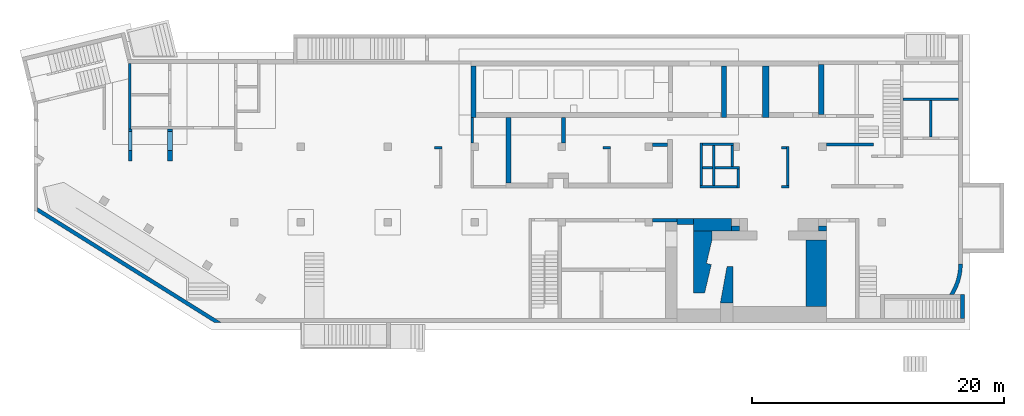
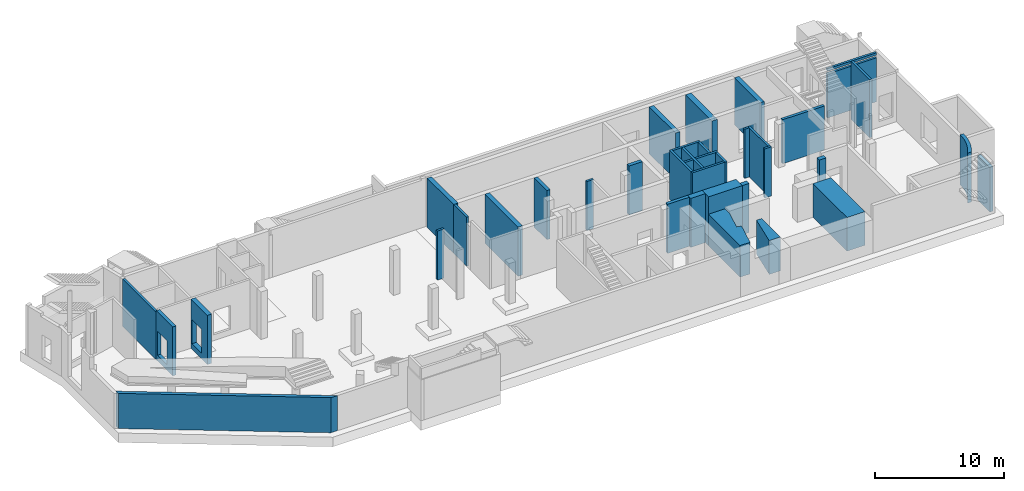
# One storey, part 3 of 9: 37 walls, 4 openings.
"""IFC4 building model written with IfcOpenShell, lengths in millimetres."""

from ifc_helpers import new_model, entity, si_unit, converted_unit, derived_unit, direction, frame, origin, place, context, subcontext, project, spatial, indexed_curve, outline, extrude, polygons, material, type_object, element, save


model = new_model("IFC4")

# Units and contexts
model_context = context("Model", 3, precision=0.01, world=origin(), true_north=direction((6.12303176911189e-17, 1.0)))
plan_context = context("Plan", 3, precision=0.01, world=origin(), true_north=direction((6.12303176911189e-17, 1.0)))
body_context = subcontext(model_context, "Body", "Model", "MODEL_VIEW")
ifc_project = project(units=[si_unit("LENGTHUNIT", "METRE", prefix="MILLI"), si_unit("AREAUNIT", "SQUARE_METRE"), si_unit("VOLUMEUNIT", "CUBIC_METRE"), converted_unit("PLANEANGLEUNIT", "DEGREE", entity("IfcRatioMeasure", 0.0174532925199433), si_unit("PLANEANGLEUNIT", "RADIAN"), dimensions=[0, 0, 0, 0, 0, 0, 0]), si_unit("MASSUNIT", "GRAM", prefix="KILO"), derived_unit("MASSDENSITYUNIT", [(si_unit("MASSUNIT", "GRAM", prefix="KILO"), 1), (si_unit("LENGTHUNIT", "METRE"), -3)]), derived_unit("MOMENTOFINERTIAUNIT", [(si_unit("LENGTHUNIT", "METRE"), 4)]), si_unit("TIMEUNIT", "SECOND"), si_unit("FREQUENCYUNIT", "HERTZ"), si_unit("THERMODYNAMICTEMPERATUREUNIT", "DEGREE_CELSIUS"), derived_unit("THERMALTRANSMITTANCEUNIT", [(si_unit("MASSUNIT", "GRAM", prefix="KILO"), 1), (si_unit("THERMODYNAMICTEMPERATUREUNIT", "KELVIN"), -1), (si_unit("TIMEUNIT", "SECOND"), -3)]), derived_unit("VOLUMETRICFLOWRATEUNIT", [(si_unit("LENGTHUNIT", "METRE"), 3), (si_unit("TIMEUNIT", "SECOND"), -1)]), derived_unit("MASSFLOWRATEUNIT", [(si_unit("MASSUNIT", "GRAM", prefix="KILO"), 1), (si_unit("TIMEUNIT", "SECOND"), -1)]), derived_unit("ROTATIONALFREQUENCYUNIT", [(si_unit("TIMEUNIT", "SECOND"), -1)]), si_unit("ELECTRICCURRENTUNIT", "AMPERE"), si_unit("ELECTRICVOLTAGEUNIT", "VOLT"), si_unit("POWERUNIT", "WATT"), si_unit("FORCEUNIT", "NEWTON", prefix="KILO"), si_unit("ILLUMINANCEUNIT", "LUX"), si_unit("LUMINOUSFLUXUNIT", "LUMEN"), si_unit("LUMINOUSINTENSITYUNIT", "CANDELA"), derived_unit("USERDEFINED", [(si_unit("MASSUNIT", "GRAM", prefix="KILO"), -1), (si_unit("LENGTHUNIT", "METRE"), -2), (si_unit("TIMEUNIT", "SECOND"), 3), (si_unit("LUMINOUSFLUXUNIT", "LUMEN"), 1)]), derived_unit("LINEARVELOCITYUNIT", [(si_unit("LENGTHUNIT", "METRE"), 1), (si_unit("TIMEUNIT", "SECOND"), -1)]), si_unit("PRESSUREUNIT", "PASCAL"), derived_unit("USERDEFINED", [(si_unit("LENGTHUNIT", "METRE"), -2), (si_unit("MASSUNIT", "GRAM", prefix="KILO"), 1), (si_unit("TIMEUNIT", "SECOND"), -2)]), derived_unit("LINEARFORCEUNIT", [(si_unit("MASSUNIT", "GRAM", prefix="KILO"), 1), (si_unit("LENGTHUNIT", "METRE"), 1), (si_unit("TIMEUNIT", "SECOND"), -2), (si_unit("LENGTHUNIT", "METRE"), -1)]), derived_unit("PLANARFORCEUNIT", [(si_unit("MASSUNIT", "GRAM", prefix="KILO"), 1), (si_unit("LENGTHUNIT", "METRE"), 1), (si_unit("TIMEUNIT", "SECOND"), -2), (si_unit("LENGTHUNIT", "METRE"), -2)])], contexts=[model_context, plan_context])

# Site, building, storey
site_placement = place(None, origin())
site = spatial("IfcSite", under=ifc_project, at=site_placement, CompositionType="ELEMENT")
building_placement = place(site_placement, origin())
building = spatial("IfcBuilding", under=site, at=building_placement, CompositionType="ELEMENT")
storey_placement = place(building_placement, frame((0.0, 0.0, -4900.0)))
storey = spatial("IfcBuildingStorey", under=building, at=storey_placement, CompositionType="ELEMENT", Elevation=-4900.0)

# Wall, opening
ifc_material = material()
wall_type_1 = type_object("IfcWallType", Name=":ADSK_ 25_200", PredefinedType="STANDARD")
placement_1 = place(storey_placement, frame((73370.0, 17470.0, 0.0), z_axis=(0.0, 0.0, 1.0), x_axis=(-1.0, 0.0, 0.0)))
wall_1 = element("IfcWall", 1, at=placement_1, inside=storey, type_object=wall_type_1, material=ifc_material, Name=":ADSK_ 25_200", ObjectType=":ADSK_ 25_200", PredefinedType="NOTDEFINED", context=body_context, shape_type="SweptSolid", body=[
    extrude(outline(indexed_curve([(4399.99999999998, 99.9999999999989), (-3.44548696094126e-13, 99.9999999999989), (3.44548696094126e-13, -99.9999999999989), (4399.99999999998, -99.9999999999989), (4399.99999999998, 99.9999999999989)], self_intersect=False)), origin(), (0.0, 0.0, 1.0), 4650.0),
])
element("IfcOpeningElement", 2, at=placement_1, cuts=wall_1, Name=":ADSK_ 25_200:1", PredefinedType="OPENING", context=body_context, shape_type="SweptSolid", body=[
    extrude(outline(indexed_curve([(-2199.99999999998, -100.0), (2199.99999999999, -100.0), (2199.99999999999, 100.0), (-2199.99999999999, 100.0), (-2199.99999999998, -100.0)], self_intersect=False)), frame((2200.0, 0.0, 4170.0)), (0.0, 0.0, 1.0), 250.0),
])

# Walls
wall_2_placement = place(storey_placement, frame((71170.0, 14470.0, -850.0), z_axis=(0.0, 0.0, 1.0), x_axis=(0.0, 1.0, 0.0)))
element("IfcWall", 3, at=wall_2_placement, inside=storey, type_object=wall_type_1, material=ifc_material, Name=":ADSK_ 25_200", ObjectType=":ADSK_ 25_200", PredefinedType="NOTDEFINED", context=body_context, shape_type="SweptSolid", body=[
    extrude(outline(indexed_curve([(2899.99999999951, 100.000000000003), (-2.98721966703065e-13, 100.000000000003), (2.98721966703065e-13, -100.000000000003), (2899.99999999951, -100.000000000003), (2899.99999999951, 100.000000000003)], self_intersect=False)), origin(), (0.0, 0.0, 1.0), 5500.0),
])
wall_3_placement = place(storey_placement, frame((34770.0, 16000.0, 0.0), z_axis=(0.0, 0.0, 1.0), x_axis=(0.0, -1.0, 0.0)))
element("IfcWall", 4, at=wall_3_placement, inside=storey, type_object=wall_type_1, material=ifc_material, Name=":ADSK_ 25_200", ObjectType=":ADSK_ 25_200", PredefinedType="NOTDEFINED", context=body_context, shape_type="SweptSolid", body=[
    extrude(outline(indexed_curve([(1999.99999999982, 99.9999999999989), (-2.16573425859696e-13, 99.9999999999989), (2.16573425859696e-13, -99.9999999999989), (1999.99999999982, -99.9999999999989), (1999.99999999982, 99.9999999999989)], self_intersect=False)), origin(), (0.0, 0.0, 1.0), 4650.0),
])
wall_4_placement = place(storey_placement, frame((59830.0, 10625.0, 0.0), z_axis=(0.0, 0.0, 1.0), x_axis=(0.0, 1.0, 0.0)))
element("IfcWall", 5, at=wall_4_placement, inside=storey, type_object=wall_type_1, material=ifc_material, Name=":ADSK_ 25_200", ObjectType=":ADSK_ 25_200", PredefinedType="NOTDEFINED", context=body_context, shape_type="SweptSolid", body=[
    extrude(outline(indexed_curve([(3075.0, 100.000000000004), (-3.08123216157509e-13, 100.000000000003), (3.08123216157509e-13, -100.000000000003), (3075.0, -100.000000000002), (3075.0, 100.000000000004)], self_intersect=False)), origin(), (0.0, 0.0, 1.0), 4650.0),
])
wall_5_placement = place(storey_placement, frame((59730.0, 13600.0, 0.0), z_axis=(0.0, 0.0, 1.0), x_axis=(-1.0, 0.0, 0.0)))
element("IfcWall", 6, at=wall_5_placement, inside=storey, type_object=wall_type_1, material=ifc_material, Name=":ADSK_ 25_200", ObjectType=":ADSK_ 25_200", PredefinedType="NOTDEFINED", context=body_context, shape_type="SweptSolid", body=[
    extrude(outline(indexed_curve([(400.000000000003, 99.9999999999983), (-9.28211303758498e-13, 99.9999999999989), (9.28211303758498e-13, -99.9999999999989), (400.000000000005, -99.9999999999995), (400.000000000003, 99.9999999999983)], self_intersect=False)), origin(), (0.0, 0.0, 1.0), 4650.0),
])
wall_6_placement = place(storey_placement, frame((59930.0, 10525.0, 0.0), z_axis=(0.0, 0.0, 1.0), x_axis=(-1.0, 0.0, 0.0)))
element("IfcWall", 7, at=wall_6_placement, inside=storey, type_object=wall_type_1, material=ifc_material, Name=":ADSK_ 25_200", ObjectType=":ADSK_ 25_200", PredefinedType="NOTDEFINED", context=body_context, shape_type="SweptSolid", body=[
    extrude(outline(indexed_curve([(600.00000000001, 99.999999999998), (-9.28211303758498e-13, 99.9999999999989), (9.28211303758498e-13, -99.9999999999989), (600.000000000012, -99.9999999999999), (600.00000000001, 99.999999999998)], self_intersect=False)), origin(), (0.0, 0.0, 1.0), 4650.0),
])
wall_7_placement = place(storey_placement, frame((55520.0, 13900.0, 0.0), z_axis=(0.0, 0.0, 1.0), x_axis=(-1.0, 0.0, 0.0)))
element("IfcWall", 8, at=wall_7_placement, inside=storey, type_object=wall_type_1, material=ifc_material, Name=":ADSK_ 25_200", ObjectType=":ADSK_ 25_200", PredefinedType="NOTDEFINED", context=body_context, shape_type="SweptSolid", body=[
    extrude(outline(indexed_curve([(2470.00000000003, 100.000000000001), (-3.39529745858372e-13, 99.9999999999989), (3.39529745858372e-13, -99.9999999999989), (2470.00000000003, -99.999999999997), (2470.00000000003, 100.000000000001)], self_intersect=False)), origin(), (0.0, 0.0, 1.0), 4650.0),
])
wall_8_placement = place(storey_placement, frame((52950.0, 14000.0, 0.0), z_axis=(0.0, 0.0, 1.0), x_axis=(0.0, -1.0, 0.0)))
element("IfcWall", 9, at=wall_8_placement, inside=storey, type_object=wall_type_1, material=ifc_material, Name=":ADSK_ 25_200", ObjectType=":ADSK_ 25_200", PredefinedType="NOTDEFINED", context=body_context, shape_type="SweptSolid", body=[
    extrude(outline(indexed_curve([(3375.00000000001, 100.000000000003), (0.0, 100.000000000003), (0.0, -100.000000000003), (3375.00000000001, -100.000000000003), (3375.00000000001, 100.000000000003)], self_intersect=False)), origin(), (0.0, 0.0, 1.0), 4650.0),
])
wall_9_placement = place(storey_placement, frame((53930.0, 13800.0, 0.0), z_axis=(0.0, 0.0, 1.0), x_axis=(0.0, -1.0, 0.0)))
element("IfcWall", 10, at=wall_9_placement, inside=storey, type_object=wall_type_1, material=ifc_material, Name=":ADSK_ 25_200", ObjectType=":ADSK_ 25_200", PredefinedType="NOTDEFINED", context=body_context, shape_type="SweptSolid", body=[
    extrude(outline(indexed_curve([(3175.00000000001, 100.000000000003), (0.0, 100.000000000003), (0.0, -100.000000000003), (3175.00000000001, -100.000000000003), (3175.00000000001, 100.000000000003)], self_intersect=False)), origin(), (0.0, 0.0, 1.0), 4650.0),
])

# Wall, opening
placement_2 = place(storey_placement, frame((53050.0, 12025.0, 0.0)))
wall_10 = element("IfcWall", 11, at=placement_2, inside=storey, type_object=wall_type_1, material=ifc_material, Name=":ADSK_ 25_200", ObjectType=":ADSK_ 25_200", PredefinedType="NOTDEFINED", context=body_context, shape_type="SweptSolid", body=[
    extrude(outline(indexed_curve([(2920.00000000003, 99.9999999999989), (0.0, 99.9999999999989), (0.0, -99.9999999999989), (2920.00000000003, -99.9999999999989), (2920.00000000003, 99.9999999999989)], self_intersect=False)), origin(), (0.0, 0.0, 1.0), 4650.0),
])
element("IfcOpeningElement", 12, at=placement_2, cuts=wall_10, Name=":ADSK_ 25_200:1", PredefinedType="OPENING", context=body_context, shape_type="SweptSolid", body=[
    extrude(outline(indexed_curve([(-2325.0, -100.000000000001), (2325.0, -100.000000000001), (2325.0, 99.9999999999989), (-2325.0, 99.9999999999989), (-2325.0, -100.000000000001)], self_intersect=False)), frame((780.0, 0.0, 2325.0), z_axis=(1.0, 0.0, 0.0), x_axis=(0.0, 0.0, -1.0)), (0.0, 0.0, 1.0), 199.999999999998),
])

# Walls
wall_11_placement = place(storey_placement, frame((55870.0, 11925.0, 0.0), z_axis=(0.0, 0.0, 1.0), x_axis=(0.0, -1.0, 0.0)))
element("IfcWall", 13, at=wall_11_placement, inside=storey, type_object=wall_type_1, material=ifc_material, Name=":ADSK_ 25_200", ObjectType=":ADSK_ 25_200", PredefinedType="NOTDEFINED", context=body_context, shape_type="SweptSolid", body=[
    extrude(outline(indexed_curve([(1500.0, 100.000000000003), (0.0, 100.000000000003), (0.0, -100.000000000003), (1500.0, -100.000000000003), (1500.0, 100.000000000003)], self_intersect=False)), origin(), (0.0, 0.0, 1.0), 4650.0),
])
wall_12_placement = place(storey_placement, frame((55420.0, 13800.0, 0.0), z_axis=(0.0, 0.0, 1.0), x_axis=(0.0, -1.0, 0.0)))
element("IfcWall", 14, at=wall_12_placement, inside=storey, type_object=wall_type_1, material=ifc_material, Name=":ADSK_ 25_200", ObjectType=":ADSK_ 25_200", PredefinedType="NOTDEFINED", context=body_context, shape_type="SweptSolid", body=[
    extrude(outline(indexed_curve([(1675.0, 100.000000000003), (0.0, 100.000000000003), (0.0, -100.000000000003), (1675.0, -100.000000000003), (1675.0, 100.000000000003)], self_intersect=False)), origin(), (0.0, 0.0, 1.0), 4650.0),
])
wall_13_placement = place(storey_placement, frame((55770.0, 10525.0, 0.0), z_axis=(0.0, 0.0, 1.0), x_axis=(-1.0, 0.0, 0.0)))
element("IfcWall", 15, at=wall_13_placement, inside=storey, type_object=wall_type_1, material=ifc_material, Name=":ADSK_ 25_200", ObjectType=":ADSK_ 25_200", PredefinedType="NOTDEFINED", context=body_context, shape_type="SweptSolid", body=[
    extrude(outline(indexed_curve([(2920.00000000003, 99.9999999999989), (0.0, 99.9999999999989), (0.0, -99.9999999999989), (2920.00000000003, -99.9999999999989), (2920.00000000003, 99.9999999999989)], self_intersect=False)), origin(), (0.0, 0.0, 1.0), 4650.0),
])
wall_14_placement = place(storey_placement, frame((45770.0, 13600.0, 0.0), z_axis=(0.0, 0.0, 1.0), x_axis=(-1.0, 0.0, 0.0)))
element("IfcWall", 16, at=wall_14_placement, inside=storey, type_object=wall_type_1, material=ifc_material, Name=":ADSK_ 25_200", ObjectType=":ADSK_ 25_200", PredefinedType="NOTDEFINED", context=body_context, shape_type="SweptSolid", body=[
    extrude(outline(indexed_curve([(600.000000000001, 99.9999999999989), (-1.08286712929837e-12, 99.9999999999989), (1.08286712929837e-12, -99.9999999999989), (600.000000000003, -99.9999999999989), (600.000000000001, 99.9999999999989)], self_intersect=False)), origin(), (0.0, 0.0, 1.0), 4650.0),
])
wall_15_placement = place(storey_placement, frame((32370.0, 13600.0, 0.0), z_axis=(0.0, 0.0, 1.0), x_axis=(-1.0, 0.0, 0.0)))
element("IfcWall", 17, at=wall_15_placement, inside=storey, type_object=wall_type_1, material=ifc_material, Name=":ADSK_ 25_200", ObjectType=":ADSK_ 25_200", PredefinedType="NOTDEFINED", context=body_context, shape_type="SweptSolid", body=[
    extrude(outline(indexed_curve([(600.000000000001, 99.9999999999984), (-9.89300764987533e-13, 99.9999999999989), (9.89300764987533e-13, -99.9999999999989), (600.000000000003, -99.9999999999995), (600.000000000001, 99.9999999999984)], self_intersect=False)), origin(), (0.0, 0.0, 1.0), 4650.0),
])
wall_16_placement = place(storey_placement, frame((7600.0, 20300.0, 0.0), z_axis=(0.0, 0.0, 1.0), x_axis=(0.0, -1.0, 0.0)))
element("IfcWall", 18, at=wall_16_placement, inside=storey, type_object=wall_type_1, material=ifc_material, Name=":ADSK_ 25_200", ObjectType=":ADSK_ 25_200", PredefinedType="NOTDEFINED", context=body_context, shape_type="Tessellation", body=[
    polygons([(0.0, -100.0, 0.0), (5200.00000000049, -99.9999999999999, 0.0), (5200.00000000049, -99.9999999999999, 4500.0), (0.0, -100.0, 4500.0), (5200.00000000049, 99.999999999999, 0.0), (5000.00000000049, 99.9999999999993, 0.0), (2600.0, 99.9999999999999, 0.0), (2400.0, 100.0, 0.0), (0.0, 99.9999999999997, 0.0), (0.0, 99.9999999999997, 4500.0), (5099.99936063356, 99.9999999999992, 4500.0), (5200.00000000049, 99.999999999999, 4500.0)], [[[1, 2, 3, 4]], [[5, 6, 7, 8, 9, 10, 11, 12]], [[2, 1, 9, 8, 7, 6, 5]], [[9, 1, 4, 10]], [[2, 5, 12, 3]], [[4, 3, 12, 11, 10]]], closed=True),
])
wall_type_2 = type_object("IfcWallType", Name=":ADSK_ 25_300", PredefinedType="STANDARD")
wall_17_placement = place(storey_placement, frame((220.51, 8728.24, 0.0), z_axis=(0.0, 0.0, 1.0), x_axis=(0.848052743777572, -0.529911826412028, 0.0)))
element("IfcWall", 19, at=wall_17_placement, inside=storey, type_object=wall_type_2, material=ifc_material, Name=":ADSK_ 25_300", ObjectType=":ADSK_ 25_300", PredefinedType="NOTDEFINED", context=body_context, shape_type="Tessellation", body=[
    polygons([(187.457147082002, -149.999999999999, 0.0), (16702.841510544, -150.000000000001, 0.0), (16702.841510544, -150.000000000001, 3330.0), (187.457147082001, -149.999999999999, 3330.0), (-1.08286712929839e-12, 150.000000000001, 0.0), (0.0, 150.000000000001, 3330.0), (16616.8193185591, 150.0, 3330.0), (17182.9512390927, 150.000000000001, 3330.0), (17182.9512390925, 149.999999999999, 0.0), (16616.8193185591, 150.000000000001, 0.0)], [[[1, 2, 3, 4]], [[5, 6, 7, 8, 9, 10]], [[2, 1, 5, 10, 9]], [[1, 4, 6, 5]], [[3, 2, 9, 8]], [[4, 3, 8, 7, 6]]], closed=True),
])
wall_18_placement = place(storey_placement, frame((49070.0, 7850.0, 0.0)))
element("IfcWall", 20, at=wall_18_placement, inside=storey, type_object=wall_type_2, material=ifc_material, Name=":ADSK_ 25_300", ObjectType=":ADSK_ 25_300", PredefinedType="NOTDEFINED", context=body_context, shape_type="SweptSolid", body=[
    extrude(outline(indexed_curve([(1950.0, 150.000000000001), (-5.11333990909232e-13, 150.000000000001), (5.11333990909232e-13, -150.000000000001), (1950.0, -150.0), (1950.0, 150.000000000001)], self_intersect=False)), origin(), (0.0, 0.0, 1.0), 4650.0),
])
wall_19_placement = place(storey_placement, frame((73675.0, 1945.0, 0.0), z_axis=(0.0, 0.0, 1.0), x_axis=(0.0, -1.0, 0.0)))
element("IfcWall", 21, at=wall_19_placement, inside=storey, type_object=wall_type_2, material=ifc_material, Name=":ADSK_ 25_300", ObjectType=":ADSK_ 25_300", PredefinedType="NOTDEFINED", context=body_context, shape_type="SweptSolid", body=[
    extrude(outline(indexed_curve([(1895.00000000003, 150.000000000001), (0.0, 150.000000000001), (0.0, -150.000000000001), (1895.00000000003, -150.000000000001), (1895.00000000003, 150.000000000001)], self_intersect=False)), origin(), (0.0, 0.0, 1.0), 4229.99999999996),
])
wall_20_placement = place(storey_placement, frame((49070.0, 13850.0, 0.0)))
element("IfcWall", 22, at=wall_20_placement, inside=storey, type_object=wall_type_2, material=ifc_material, Name=":ADSK_ 25_300", ObjectType=":ADSK_ 25_300", PredefinedType="NOTDEFINED", context=body_context, shape_type="SweptSolid", body=[
    extrude(outline(indexed_curve([(1200.0, 150.000000000001), (-5.41433564649196e-13, 150.000000000001), (5.41433564649196e-13, -150.000000000001), (1200.00000000001, -150.000000000001), (1200.0, 150.000000000001)], self_intersect=False)), origin(), (0.0, 0.0, 1.0), 4650.0),
])
wall_21_placement = place(storey_placement, frame((42020.0, 14000.0, 0.0), z_axis=(0.0, 0.0, 1.0), x_axis=(0.0, 1.0, 0.0)))
element("IfcWall", 23, at=wall_21_placement, inside=storey, type_object=wall_type_2, material=ifc_material, Name=":ADSK_ 25_300", ObjectType=":ADSK_ 25_300", PredefinedType="NOTDEFINED", context=body_context, shape_type="SweptSolid", body=[
    extrude(outline(indexed_curve([(1999.99999999982, 150.000000000001), (0.0, 150.000000000001), (0.0, -150.000000000001), (1999.99999999982, -150.000000000001), (1999.99999999982, 150.000000000001)], self_intersect=False)), origin(), (0.0, 0.0, 1.0), 4650.0),
])

# Wall, opening
wall_22_placement = place(storey_placement, frame((7650.0, 15100.0, 0.0), z_axis=(0.0, 0.0, 1.0), x_axis=(0.0, -1.0, 0.0)))
wall_22 = element("IfcWall", 24, at=wall_22_placement, inside=storey, type_object=wall_type_2, material=ifc_material, Name=":ADSK_ 25_300", ObjectType=":ADSK_ 25_300", PredefinedType="NOTDEFINED", context=body_context, shape_type="Tessellation", body=[
    polygons([(0.0, -149.999999999999, 0.0), (2559.99999999952, -149.999999999999, 0.0), (2559.99999999952, -149.999999999999, 4650.0), (0.0, -149.999999999999, 4650.0), (0.0, -149.999999999999, 4500.0), (199.999999999524, -149.999999999999, 2829.99999999804), (1699.99999999952, -150.0, 2829.99999999805), (1699.99999999952, -150.0, 550.0), (199.999999999521, -149.999999999999, 550.0), (2559.99999999952, 150.000000000001, 0.0), (0.0, 150.000000000001, 0.0), (0.0, 150.000000000001, 4650.0), (2559.99999999952, 150.000000000001, 4650.0), (1699.99999999952, 150.0, 2829.99999999805), (199.999999999521, 150.000000000001, 2829.99999999804), (199.999999999521, 150.000000000001, 550.0), (1699.99999999952, 150.0, 550.0), (0.0, 50.0000000000028, 0.0), (0.0, 50.0000000000039, 4650.0)], [[[1, 2, 3, 4, 5], [6, 7, 8, 9]], [[10, 11, 12, 13], [14, 15, 16, 17]], [[2, 1, 18, 11, 10]], [[3, 2, 10, 13]], [[4, 3, 13, 12, 19]], [[1, 5, 4, 19, 12, 11, 18]], [[14, 7, 6, 15]], [[15, 6, 9, 16]], [[16, 9, 8, 17]], [[7, 14, 17, 8]]], closed=True),
])
opening_3_placement = place(wall_22_placement, frame((15100.0, -7650.0, 0.0), z_axis=(0.0, 0.0, 1.0), x_axis=(0.0, 1.0, 0.0)))
element("IfcOpeningElement", 25, at=opening_3_placement, cuts=wall_22, Name=":ADSK_ 25_300", PredefinedType="OPENING", context=body_context, shape_type="SweptSolid", body=[
    extrude(outline(indexed_curve([(-1139.99999999902, -749.999999999998), (1139.99999999902, -749.999999999998), (1139.99999999902, 750.000000000001), (-1139.99999999902, 750.000000000001), (-1139.99999999902, -749.999999999998)], self_intersect=False)), frame((7400.0, 14150.0, 1690.0), z_axis=(1.0, 0.0, 0.0), x_axis=(0.0, 0.0, -1.0)), (0.0, 0.0, 1.0), 500.000000001943),
])

# Walls
wall_23_placement = place(storey_placement, frame((73520.0, 4400.0, 0.0)))
element("IfcWall", 26, at=wall_23_placement, inside=storey, type_object=wall_type_2, material=ifc_material, Name=":ADSK_ 25_300", ObjectType=":ADSK_ 25_300", PredefinedType="NOTDEFINED", context=body_context, shape_type="SweptSolid", body=[
    extrude(outline(indexed_curve([(-542.136329488565, -2454.9999999995), (-413.330459406746, -2231.13461263897), (-297.016369515146, -2000.53171517602), (-193.545301320908, -1763.88767474322), (-103.229713391773, -1521.91710132026), (-26.3423378039082, -1275.350689778), (36.8846434456006, -1024.93301334981), (86.2602995743678, -771.420275193577), (121.635527581284, -515.578024833953), (142.9035025029, -258.178846380812), (150.000000000001, -2.55048707444416e-05), (-149.999999999992, 2.55047527119245e-05), (-157.705892452505, -260.292278133518), (-180.796490186139, -519.67286416129), (-219.190914727773, -777.233211023775), (-272.754683528757, -1032.07117284195), (-341.300181011307, -1283.29413932128), (-424.587315721797, -1530.02216226056), (-522.324361289021, -1771.39103770973), (-634.168978242002, -2006.55533298103), (-759.729413108203, -2234.69134791076), (-898.565870592014, -2454.99999999949), (-542.136329488565, -2454.9999999995)], self_intersect=False)), origin(), (0.0, 0.0, 1.0), 4750.0),
])
wall_type_3 = type_object("IfcWallType", Name=":ADSK_ 25_250", PredefinedType="STANDARD")
wall_24_placement = place(storey_placement, frame((62870.0, 13875.0, 0.0)))
element("IfcWall", 27, at=wall_24_placement, inside=storey, type_object=wall_type_3, material=ifc_material, Name=":ADSK_ 25_250", ObjectType=":ADSK_ 25_250", PredefinedType="NOTDEFINED", context=body_context, shape_type="SweptSolid", body=[
    extrude(outline(indexed_curve([(3759.99999999999, 124.999999999999), (-3.94184035522033e-13, 125.0), (3.94184035522033e-13, -125.0), (3759.99999999999, -125.000000000001), (3759.99999999999, 124.999999999999)], self_intersect=False)), origin(), (0.0, 0.0, 1.0), 4170.0),
])
wall_type_4 = type_object("IfcWallType", Name=":ADSK_ 25_1000", PredefinedType="STANDARD")
wall_25_placement = place(storey_placement, frame((52320.0, 7500.0, 0.0)))
element("IfcWall", 28, at=wall_25_placement, inside=storey, type_object=wall_type_4, material=ifc_material, Name=":ADSK_ 25_1000", ObjectType=":ADSK_ 25_1000", PredefinedType="NOTDEFINED", context=body_context, shape_type="SweptSolid", body=[
    extrude(outline(indexed_curve([(3050.00000000001, 500.0), (-1.54352002599108e-12, 500.0), (1.54352002599108e-12, -500.0), (3050.00000000001, -500.0), (3050.00000000001, 500.0)], self_intersect=False)), origin(), (0.0, 0.0, 1.0), 4650.0),
])
wall_type_5 = type_object("IfcWallType", Name="1: 1", PredefinedType="NOTDEFINED", material=ifc_material)
wall_26_placement = place(storey_placement, frame((54470.0, 1300.0, 0.0), z_axis=(0.0, 0.0, 1.0), x_axis=(0.0, 1.0, 0.0)))
element("IfcWall", 29, at=wall_26_placement, inside=storey, type_object=wall_type_5, material=ifc_material, Name="1: 1", ObjectType="1: 1", PredefinedType="NOTDEFINED", context=body_context, shape_type="SweptSolid", body=[
    extrude(outline(indexed_curve([(-368.249999999999, -1450.0), (104.749999999998, -1450.0), (631.749999999999, 1450.0), (-368.249999999999, 1450.0), (-368.249999999999, -1450.0)], self_intersect=False)), frame((1450.0, -631.75, 0.0), z_axis=(0.0, 0.0, 1.0), x_axis=(0.0, 1.0, 0.0)), (0.0, 0.0, 1.0), 3200.0),
])
wall_type_6 = type_object("IfcWallType", Name=":ADSK_ 25_500", PredefinedType="STANDARD")
wall_27_placement = place(storey_placement, frame((50570.0, 7750.0, 0.0)))
element("IfcWall", 30, at=wall_27_placement, inside=storey, type_object=wall_type_6, material=ifc_material, Name=":ADSK_ 25_500", ObjectType=":ADSK_ 25_500", PredefinedType="NOTDEFINED", context=body_context, shape_type="SweptSolid", body=[
    extrude(outline(indexed_curve([(1750.0, -250.000000000001), (1750.0, 249.999999999999), (450.000000000001, 249.999999999999), (450.000000000002, -50.0000000000001), (450.000000000002, -250.000000000001), (1750.0, -250.000000000001)], self_intersect=False)), origin(), (0.0, 0.0, 1.0), 4650.0),
])
wall_28_placement = place(storey_placement, frame((58070.0, 20100.0, 0.0), z_axis=(0.0, 0.0, 1.0), x_axis=(0.0, -1.0, 0.0)))
element("IfcWall", 31, at=wall_28_placement, inside=storey, type_object=wall_type_6, material=ifc_material, Name=":ADSK_ 25_500", ObjectType=":ADSK_ 25_500", PredefinedType="NOTDEFINED", context=body_context, shape_type="SweptSolid", body=[
    extrude(outline(indexed_curve([(4100.00000000002, 250.000000000004), (0.0, 250.000000000004), (0.0, -250.000000000004), (4100.00000000002, -250.000000000004), (4100.00000000002, 250.000000000004)], self_intersect=False)), origin(), (0.0, 0.0, 1.0), 4450.0),
])
wall_type_7 = type_object("IfcWallType", Name=":ADSK_ 25_400", PredefinedType="STANDARD")
wall_29_placement = place(storey_placement, frame((55370.0, 7200.0, 0.0)))
element("IfcWall", 32, at=wall_29_placement, inside=storey, type_object=wall_type_7, material=ifc_material, Name=":ADSK_ 25_400", ObjectType=":ADSK_ 25_400", PredefinedType="NOTDEFINED", context=body_context, shape_type="SweptSolid", body=[
    extrude(outline(indexed_curve([(600.000000000001, 200.0), (-1.44382283906452e-12, 200.0), (1.44382283906452e-12, -200.0), (600.000000000004, -200.0), (600.000000000001, 200.0)], self_intersect=False)), origin(), (0.0, 0.0, 1.0), 4650.0),
])
wall_30_placement = place(storey_placement, frame((62270.0, 7200.0, 0.0)))
element("IfcWall", 33, at=wall_30_placement, inside=storey, type_object=wall_type_7, material=ifc_material, Name=":ADSK_ 25_400", ObjectType=":ADSK_ 25_400", PredefinedType="NOTDEFINED", context=body_context, shape_type="SweptSolid", body=[
    extrude(outline(indexed_curve([(600.000000000001, 200.0), (-7.21911419532259e-13, 200.0), (7.21911419532259e-13, -200.0), (600.000000000003, -200.0), (600.000000000001, 200.0)], self_intersect=False)), origin(), (0.0, 0.0, 1.0), 4650.0),
])
wall_31_placement = place(storey_placement, frame((62470.0, 20500.0, 0.0), z_axis=(0.0, 0.0, 1.0), x_axis=(0.0, -1.0, 0.0)))
element("IfcWall", 34, at=wall_31_placement, inside=storey, type_object=wall_type_7, material=ifc_material, Name=":ADSK_ 25_400", ObjectType=":ADSK_ 25_400", PredefinedType="NOTDEFINED", context=body_context, shape_type="SweptSolid", body=[
    extrude(outline(indexed_curve([(4250.00000000001, -199.999999999993), (4250.00000000001, 200.000000000003), (300.000000000005, 199.999999999999), (300.000000000006, -199.999999999997), (400.000000000001, -199.999999999997), (4100.00000000001, -199.999999999993), (4250.00000000001, -199.999999999993)], self_intersect=False)), origin(), (0.0, 0.0, 1.0), 4450.0),
])
wall_32_placement = place(storey_placement, frame((34870.0, 20500.0, 0.0), z_axis=(0.0, 0.0, 1.0), x_axis=(0.0, -1.0, 0.0)))
element("IfcWall", 35, at=wall_32_placement, inside=storey, type_object=wall_type_7, material=ifc_material, Name=":ADSK_ 25_400", ObjectType=":ADSK_ 25_400", PredefinedType="NOTDEFINED", context=body_context, shape_type="SweptSolid", body=[
    extrude(outline(indexed_curve([(4500.00000000001, -199.999999999998), (4500.00000000001, 0.0), (4500.00000000001, 200.000000000002), (4100.00000000001, 200.000000000002), (400.0, 200.000000000002), (399.999999999996, -199.999999999998), (4500.00000000001, -199.999999999998)], self_intersect=False)), origin(), (0.0, 0.0, 1.0), 4650.0),
])
wall_33_placement = place(storey_placement, frame((54770.0, 20100.0, 0.0), z_axis=(0.0, 0.0, 1.0), x_axis=(0.0, -1.0, 0.0)))
element("IfcWall", 36, at=wall_33_placement, inside=storey, type_object=wall_type_7, material=ifc_material, Name=":ADSK_ 25_400", ObjectType=":ADSK_ 25_400", PredefinedType="NOTDEFINED", context=body_context, shape_type="SweptSolid", body=[
    extrude(outline(indexed_curve([(4100.00000000001, 199.999999999998), (0.0, 199.999999999998), (0.0, -199.999999999998), (4100.00000000001, -199.999999999998), (4100.00000000001, 199.999999999998)], self_intersect=False)), origin(), (0.0, 0.0, 1.0), 4450.0),
])
wall_34_placement = place(storey_placement, frame((37665.0, 10825.0, 0.0), z_axis=(0.0, 0.0, 1.0), x_axis=(0.0, 1.0, 0.0)))
element("IfcWall", 37, at=wall_34_placement, inside=storey, type_object=wall_type_7, material=ifc_material, Name=":ADSK_ 25_400", ObjectType=":ADSK_ 25_400", PredefinedType="NOTDEFINED", context=body_context, shape_type="SweptSolid", body=[
    extrude(outline(indexed_curve([(5174.99999999991, 199.999999999996), (-4.14990995659274e-13, 199.999999999998), (4.14990995659274e-13, -199.999999999998), (5174.99999999991, -200.0), (5174.99999999991, 199.999999999996)], self_intersect=False)), origin(), (0.0, 0.0, 1.0), 4650.0),
])

# Wall, opening
wall_35_placement = place(storey_placement, frame((10800.0, 12540.0, 0.0), z_axis=(0.0, 0.0, 1.0), x_axis=(0.0, 1.0, 0.0)))
wall_35 = element("IfcWall", 38, at=wall_35_placement, inside=storey, type_object=wall_type_7, material=ifc_material, Name=":ADSK_ 25_400", ObjectType=":ADSK_ 25_400", PredefinedType="NOTDEFINED", context=body_context, shape_type="Tessellation", body=[
    polygons([(0.0, -200.000000000001, 0.0), (2559.99999999951, -200.0, 0.0), (2559.99999999951, -200.0, 4650.0), (0.0, -200.000000000001, 4650.0), (860.000000000004, -200.000000000001, 2829.99999999804), (2360.0, -200.000000000001, 2829.99999999805), (2360.0, -200.000000000001, 550.0), (860.000000000002, -200.000000000001, 550.0), (2559.99999999951, 200.0, 0.0), (0.0, 199.999999999999, 0.0), (0.0, 199.999999999999, 4650.0), (2559.99999999951, 200.0, 4650.0), (2360.0, 199.999999999999, 2829.99999999805), (860.000000000006, 199.999999999999, 2829.99999999804), (860.000000000002, 199.999999999999, 550.0), (2360.0, 199.999999999999, 550.0)], [[[1, 2, 3, 4], [5, 6, 7, 8]], [[9, 10, 11, 12], [13, 14, 15, 16]], [[2, 1, 10, 9]], [[4, 3, 12, 11]], [[1, 4, 11, 10]], [[3, 2, 9, 12]], [[13, 6, 5, 14]], [[14, 5, 8, 15]], [[15, 8, 7, 16]], [[6, 13, 16, 7]]], closed=True),
])
opening_4_placement = place(wall_35_placement, frame((-12540.0, 10800.0, 0.0), z_axis=(0.0, 0.0, 1.0), x_axis=(0.0, -1.0, 0.0)))
element("IfcOpeningElement", 39, at=opening_4_placement, cuts=wall_35, Name=":ADSK_ 25_400", PredefinedType="OPENING", context=body_context, shape_type="SweptSolid", body=[
    extrude(outline(indexed_curve([(-1139.99999999902, -750.000000000001), (1139.99999999902, -750.000000000001), (1139.99999999902, 749.999999999998), (-1139.99999999902, 749.999999999998), (-1139.99999999902, -750.000000000001)], self_intersect=False)), frame((11100.0, 14150.0, 1690.0), z_axis=(-1.0, 0.0, 0.0), x_axis=(0.0, 0.0, -1.0)), (0.0, 0.0, 1.0), 600.000000001943),
])

# Walls
wall_type_8 = type_object("IfcWallType", Name="2: 2", PredefinedType="NOTDEFINED", material=ifc_material)
wall_36_placement = place(storey_placement, frame((52320.0, 2100.0, 0.0), z_axis=(0.0, 0.0, 1.0), x_axis=(0.0, 1.0, 0.0)))
element("IfcWall", 40, at=wall_36_placement, inside=storey, type_object=wall_type_8, material=ifc_material, Name="2: 2", ObjectType="2: 2", PredefinedType="NOTDEFINED", context=body_context, shape_type="SweptSolid", body=[
    extrude(outline(indexed_curve([(-905.604757595647, -2654.02109078585), (-5.60475759564329, -2654.02109078585), (525.395242404358, -411.021090785853), (136.153912030035, -318.873455284841), (577.632559176254, 1545.97890921415), (577.632559176254, 2245.97890921412), (-905.604757595645, 2245.97890921412), (-905.604757595647, -2654.02109078585)], self_intersect=False)), frame((2654.02, -905.6, 0.0), z_axis=(0.0, 0.0, 1.0), x_axis=(0.0, -1.0, 0.0)), (0.0, 0.0, 1.0), 3000.0),
])
wall_type_9 = type_object("IfcWallType", Name=":ADSK_ 25_1600", PredefinedType="STANDARD")
wall_37_placement = place(storey_placement, frame((62070.0, 1000.0, 0.0), z_axis=(0.0, 0.0, 1.0), x_axis=(0.0, 1.0, 0.0)))
element("IfcWall", 41, at=wall_37_placement, inside=storey, type_object=wall_type_9, material=ifc_material, Name=":ADSK_ 25_1600", ObjectType=":ADSK_ 25_1600", PredefinedType="NOTDEFINED", context=body_context, shape_type="SweptSolid", body=[
    extrude(outline(indexed_curve([(-799.999999999991, -2650.0), (800.000000000009, -2650.0), (799.999999999991, 2650.0), (-800.000000000009, 2650.00000000001), (-799.999999999991, -2650.0)], self_intersect=False)), frame((2650.0, 0.0, 0.0), z_axis=(0.0, 0.0, 1.0), x_axis=(0.0, 1.0, 0.0)), (0.0, 0.0, 1.0), 3200.0),
])

save(model, "model.ifc")
